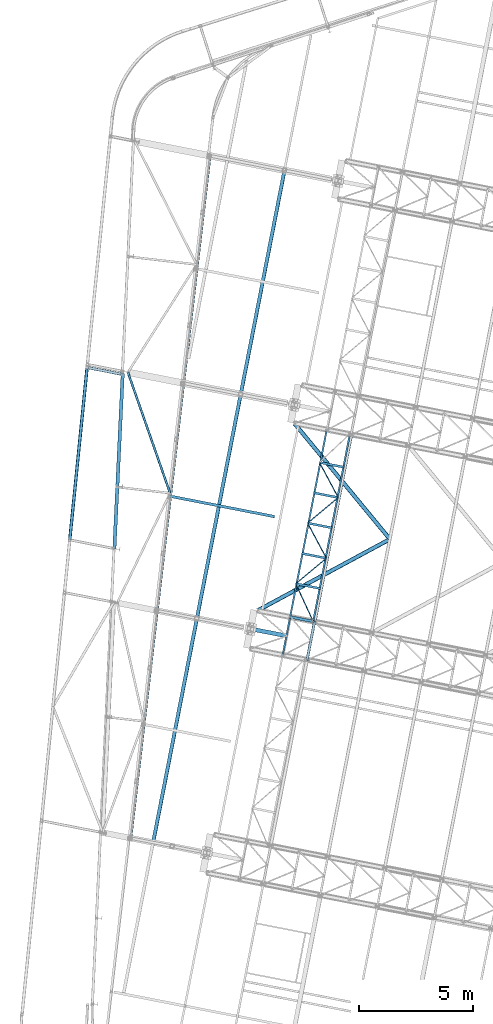
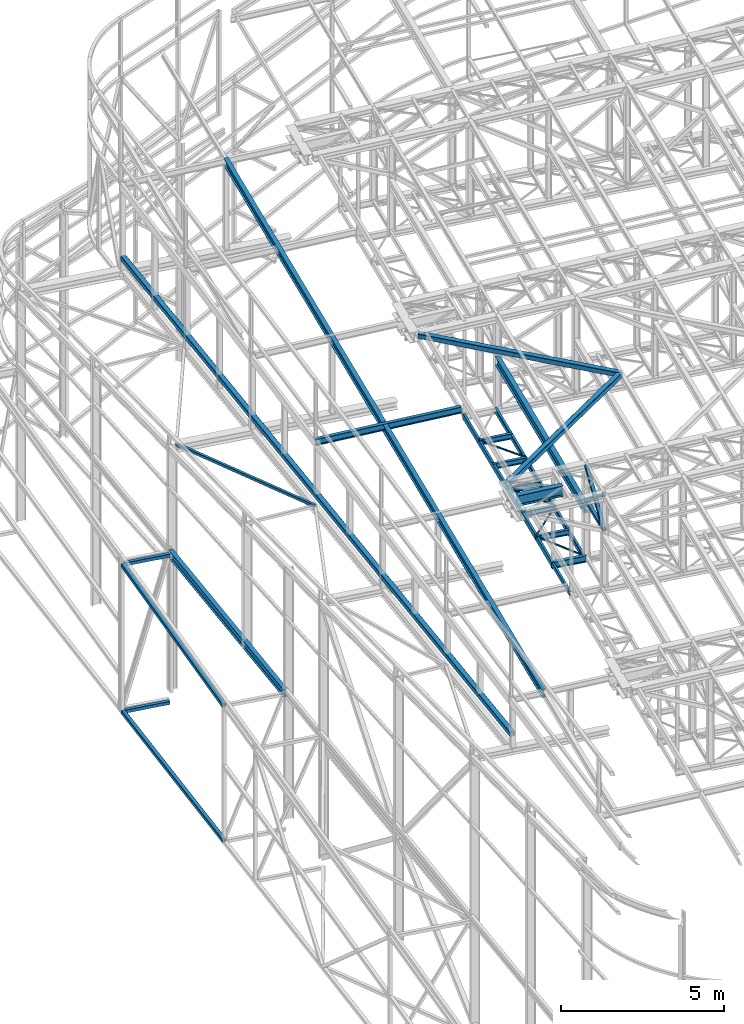
# One storey, part 70 of 215: 28 beams, 2 members, 30 elements without a shape of their own.
"""IFC2X3 building model written with IfcOpenShell, lengths in millimetres."""

from ifc_helpers import new_model, si_unit, frame, origin_with_axes, origin_2d_with_axis, place, context, subcontext, project, spatial, hollow_rectangle, i_section, u_section, extrude, clip, halfspace, material, type_object, element, aggregate, save


model = new_model("IFC2X3")

# Units and contexts
model_context = context("Model", 3, precision=1e-05, world=origin_with_axes())
body_context = subcontext(model_context, "Body", "Model", "MODEL_VIEW")
ifc_project = project(units=[si_unit("LENGTHUNIT", "METRE", prefix="MILLI"), si_unit("AREAUNIT", "SQUARE_METRE"), si_unit("VOLUMEUNIT", "CUBIC_METRE"), si_unit("MASSUNIT", "GRAM", prefix="KILO"), si_unit("TIMEUNIT", "SECOND"), si_unit("PLANEANGLEUNIT", "RADIAN"), si_unit("SOLIDANGLEUNIT", "STERADIAN"), si_unit("THERMODYNAMICTEMPERATUREUNIT", "DEGREE_CELSIUS"), si_unit("LUMINOUSINTENSITYUNIT", "LUMEN")], contexts=[model_context])

# Site, building, storey
site_placement = place(None, origin_with_axes())
site = spatial("IfcSite", under=ifc_project, at=site_placement, CompositionType="ELEMENT")
building_placement = place(site_placement, origin_with_axes())
building = spatial("IfcBuilding", under=site, at=building_placement, Name="Undefined", CompositionType="ELEMENT")
storey_placement = place(building_placement, origin_with_axes())
storey = spatial("IfcBuildingStorey", under=building, at=storey_placement, Name="Undefined", CompositionType="ELEMENT", Elevation=0.0)

# Assembly, beam
assembly_1_placement = place(storey_placement, origin_with_axes())
assembly_1 = element("IfcElementAssembly", 1, at=assembly_1_placement, inside=storey, Name="Steel Assembly", AssemblyPlace="NOTDEFINED", PredefinedType="RIGID_FRAME")
ifc_material_1 = material(Name="STEEL/S355JR")
beam_type_1 = type_object("IfcBeamType", Name="IPE240", PredefinedType="NOTDEFINED")
beam_1_placement = place(assembly_1_placement, frame((45870.7197562295, 33525.8888527729, 8620.00000000187), z_axis=(0.0, 0.0, 1.0), x_axis=(0.981422409205525, -0.19185946604018, 1.89999991602007e-08)))
beam_1 = element("IfcBeam", 2, at=beam_1_placement, type_object=beam_type_1, material=ifc_material_1, ObjectType="IPE240", context=body_context, shape_type="SweptSolid", body=[
    extrude(i_section(OverallWidth=120.0, OverallDepth=240.0, WebThickness=6.199999809, FlangeThickness=9.800000191, FilletRadius=15.0, at=origin_2d_with_axis()), frame((1125.79486349449, 0.0, 0.0), z_axis=(-1.0, 0.0, 0.0), x_axis=(-6.93889390390723e-18, -1.0, -3.46944695195361e-18)), (0.0, 0.0, 1.0), 1125.8),
])
aggregate(assembly_1, [beam_1])

assembly_2_placement = place(storey_placement, origin_with_axes())
assembly_2 = element("IfcElementAssembly", 3, at=assembly_2_placement, inside=storey, Name="Steel Assembly", AssemblyPlace="NOTDEFINED", PredefinedType="RIGID_FRAME")
ifc_material_2 = material(Name="STEEL/S275JR")
beam_2_placement = place(assembly_2_placement, frame((40574.7007247499, 38820.9318714766, 11862.6457779007), z_axis=(-0.0304080349967745, 0.00594450299936818, 0.999519891893966), x_axis=(0.980951223231219, -0.191767338045201, 0.0309836360073031)))
beam_2 = element("IfcBeam", 4, at=beam_2_placement, type_object=beam_type_1, material=ifc_material_2, Name="TRAVERSE", ObjectType="IPE240", context=body_context, shape_type="SweptSolid", body=[
    extrude(i_section(OverallWidth=120.0, OverallDepth=240.0, WebThickness=6.199999809, FlangeThickness=9.800000191, FilletRadius=15.0, at=origin_2d_with_axis()), frame((4735.84548835721, -7.39508111654668e-12, 1.64307646945042e-14), z_axis=(-1.0, 0.0, 0.0), x_axis=(-6.93889390390723e-18, -1.0, -3.46944695195361e-18)), (0.0, 0.0, 1.0), 4735.8),
])
aggregate(assembly_2, [beam_2])

assembly_3_placement = place(storey_placement, origin_with_axes())
assembly_3 = element("IfcElementAssembly", 5, at=assembly_3_placement, inside=storey, Name="Steel Assembly", AssemblyPlace="NOTDEFINED", PredefinedType="RIGID_FRAME")
ifc_material_3 = material(Name="STEEL/S235JR")
beam_type_2 = type_object("IfcBeamType", PredefinedType="NOTDEFINED")
beam_3_placement = place(assembly_3_placement, frame((38507.9983066721, 44152.2773014969, 5130.81618442959), z_axis=(0.0, 0.0, 1.0), x_axis=(-0.981475092367809, 0.1915897780718, 0.0)))
beam_3 = element("IfcBeam", 6, at=beam_3_placement, type_object=beam_type_2, material=ifc_material_3, Name="LISSE", context=body_context, shape_type="SweptSolid", body=[
    extrude(hollow_rectangle(XDim=120.0, YDim=120.0, WallThickness=4.0, InnerFilletRadius=4.0, OuterFilletRadius=8.0, at=origin_2d_with_axis()), frame((1466.23896140756, -4.06963063639286e-14, -9.09494701772928e-13), z_axis=(-1.0, 0.0, 0.0), x_axis=(-6.93889390390723e-18, -1.0, -3.46944695195361e-18)), (0.0, 0.0, 1.0), 1466.2),
])
aggregate(assembly_3, [beam_3])

assembly_4_placement = place(storey_placement, origin_with_axes())
assembly_4 = element("IfcElementAssembly", 7, at=assembly_4_placement, inside=storey, Name="Steel Assembly", AssemblyPlace="NOTDEFINED", PredefinedType="RIGID_FRAME")
beam_4_placement = place(assembly_4_placement, frame((38507.9983066069, 44152.2773015299, -367.578507559147), z_axis=(0.0, 0.0, 1.0), x_axis=(-0.981475092367809, 0.1915897780718, 0.0)))
beam_4 = element("IfcBeam", 8, at=beam_4_placement, type_object=beam_type_2, material=ifc_material_3, Name="LISSE", context=body_context, shape_type="SweptSolid", body=[
    extrude(hollow_rectangle(XDim=120.0, YDim=120.0, WallThickness=4.0, InnerFilletRadius=4.0, OuterFilletRadius=8.0, at=origin_2d_with_axis()), frame((1466.23896140756, -4.06963063639286e-14, -9.09494701772928e-13), z_axis=(-1.0, 0.0, 0.0), x_axis=(-6.93889390390723e-18, -1.0, -3.46944695195361e-18)), (0.0, 0.0, 1.0), 1466.2),
])
aggregate(assembly_4, [beam_4])

assembly_5_placement = place(storey_placement, origin_with_axes())
assembly_5 = element("IfcElementAssembly", 9, at=assembly_5_placement, inside=storey, Name="Steel Assembly", AssemblyPlace="NOTDEFINED", PredefinedType="RIGID_FRAME")
beam_type_3 = type_object("IfcBeamType", PredefinedType="NOTDEFINED")
beam_5_placement = place(assembly_5_placement, frame((46649.4384347017, 31641.4766982713, 10796.0000009258), z_axis=(0.981422364268518, -0.191859461052493, -0.000300197000082615), x_axis=(0.191859470081235, 0.981422408415534, 0.0)))
beam_5 = element("IfcBeam", 10, at=beam_5_placement, type_object=beam_type_3, material=ifc_material_2, context=body_context, shape_type="SweptSolid", body=[
    extrude(hollow_rectangle(XDim=120.0, YDim=120.0, WallThickness=5.0, InnerFilletRadius=5.0, OuterFilletRadius=10.0, at=origin_2d_with_axis()), frame((1699.99999941724, 1.81898940354586e-12, 0.0), z_axis=(-1.0, 0.0, 0.0), x_axis=(-6.93889390390723e-18, -1.0, -3.46944695195361e-18)), (0.0, 0.0, 1.0), 1700.0),
])
aggregate(assembly_5, [beam_5])

assembly_6_placement = place(storey_placement, origin_with_axes())
assembly_6 = element("IfcElementAssembly", 11, at=assembly_6_placement, inside=storey, Name="Steel Assembly", AssemblyPlace="NOTDEFINED", PredefinedType="RIGID_FRAME")
beam_type_4 = type_object("IfcBeamType", PredefinedType="NOTDEFINED")
beam_6_placement = place(assembly_6_placement, frame((38802.4008406936, 44229.2659145975, 9116.34802934099), z_axis=(0.944199061956866, 0.328656952984984, -0.0217425539990071), x_axis=(0.329325113950894, -0.943148942859368, 0.0448892069933065)))
beam_6 = element("IfcBeam", 12, at=beam_6_placement, type_object=beam_type_4, material=ifc_material_2, context=body_context, shape_type="SweptSolid", body=[
    extrude(hollow_rectangle(XDim=100.0, YDim=100.0, WallThickness=5.0, InnerFilletRadius=5.0, OuterFilletRadius=10.0, at=origin_2d_with_axis()), frame((5609.32447625776, -1.8579119109592e-12, 7.05470446866834e-14), z_axis=(-1.0, 0.0, 0.0), x_axis=(-6.93889390390723e-18, -1.0, -3.46944695195361e-18)), (0.0, 0.0, 1.0), 5609.3),
])
aggregate(assembly_6, [beam_6])

assembly_7_placement = place(storey_placement, origin_with_axes())
assembly_7 = element("IfcElementAssembly", 13, at=assembly_7_placement, inside=storey, Name="Steel Assembly", AssemblyPlace="NOTDEFINED", PredefinedType="RIGID_FRAME")
beam_type_5 = type_object("IfcBeamType", PredefinedType="NOTDEFINED")
beam_7_placement = place(assembly_7_placement, frame((46153.4358061915, 34972.080709326, 8715.68808125005), z_axis=(0.0, 0.0, -1.0), x_axis=(0.419988254111175, -0.907529540240232, 0.0)))
beam_7 = element("IfcBeam", 14, at=beam_7_placement, type_object=beam_type_5, material=ifc_material_2, context=body_context, shape_type="SweptSolid", body=[
    extrude(hollow_rectangle(XDim=50.0, YDim=50.0, WallThickness=3.0, InnerFilletRadius=3.0, OuterFilletRadius=6.0, at=origin_2d_with_axis()), frame((1819.0177301871, 0.0, 0.0), z_axis=(-1.0, 0.0, 0.0), x_axis=(-6.93889390390723e-18, -1.0, -3.46944695195361e-18)), (0.0, 0.0, 1.0), 1819.0),
])
aggregate(assembly_7, [beam_7])

assembly_8_placement = place(storey_placement, origin_with_axes())
assembly_8 = element("IfcElementAssembly", 15, at=assembly_8_placement, inside=storey, Name="Steel Assembly", AssemblyPlace="NOTDEFINED", PredefinedType="RIGID_FRAME")
beam_8_placement = place(assembly_8_placement, frame((47493.9963179093, 36089.2001487748, 8715.68808125022), z_axis=(0.0, 0.0, -1.0), x_axis=(-0.768225315975549, -0.640179555979623, 0.0)))
beam_8 = element("IfcBeam", 16, at=beam_8_placement, type_object=beam_type_5, material=ifc_material_2, context=body_context, shape_type="SweptSolid", body=[
    extrude(hollow_rectangle(XDim=50.0, YDim=50.0, WallThickness=3.0, InnerFilletRadius=3.0, OuterFilletRadius=6.0, at=origin_2d_with_axis()), frame((1745.00954958407, -3.57879861879514e-13, 0.0), z_axis=(-1.0, 0.0, 0.0), x_axis=(-6.93889390390723e-18, -1.0, -3.46944695195361e-18)), (0.0, 0.0, 1.0), 1745.0),
])
aggregate(assembly_8, [beam_8])

assembly_9_placement = place(storey_placement, origin_with_axes())
assembly_9 = element("IfcElementAssembly", 17, at=assembly_9_placement, inside=storey, Name="Steel Assembly", AssemblyPlace="NOTDEFINED", PredefinedType="RIGID_FRAME")
beam_9_placement = place(assembly_9_placement, frame((46672.828634124, 37628.9216759817, 8715.68808124293), z_axis=(0.0, 0.0, -1.0), x_axis=(0.470580592231475, -0.882357017434029, 0.0)))
beam_9 = element("IfcBeam", 18, at=beam_9_placement, type_object=beam_type_5, material=ifc_material_2, context=body_context, shape_type="SweptSolid", body=[
    extrude(hollow_rectangle(XDim=50.0, YDim=50.0, WallThickness=3.0, InnerFilletRadius=3.0, OuterFilletRadius=6.0, at=origin_2d_with_axis()), frame((1745.0096693843, 0.0, 0.0), z_axis=(-1.0, 0.0, 0.0), x_axis=(-6.93889390390723e-18, -1.0, -3.46944695195361e-18)), (0.0, 0.0, 1.0), 1745.0),
])
aggregate(assembly_9, [beam_9])

assembly_10_placement = place(storey_placement, origin_with_axes())
assembly_10 = element("IfcElementAssembly", 19, at=assembly_10_placement, inside=storey, Name="Steel Assembly", AssemblyPlace="NOTDEFINED", PredefinedType="RIGID_FRAME")
beam_10_placement = place(assembly_10_placement, frame((48013.3891458419, 38746.0411154303, 8715.6880812431), z_axis=(0.0, 0.0, -1.0), x_axis=(-0.768225315975549, -0.640179555979623, 0.0)))
beam_10 = element("IfcBeam", 20, at=beam_10_placement, type_object=beam_type_5, material=ifc_material_2, context=body_context, shape_type="SweptSolid", body=[
    extrude(hollow_rectangle(XDim=50.0, YDim=50.0, WallThickness=3.0, InnerFilletRadius=3.0, OuterFilletRadius=6.0, at=origin_2d_with_axis()), frame((1745.00954958407, -3.57879861879514e-13, 0.0), z_axis=(-1.0, 0.0, 0.0), x_axis=(-6.93889390390723e-18, -1.0, -3.46944695195361e-18)), (0.0, 0.0, 1.0), 1745.0),
])
aggregate(assembly_10, [beam_10])

assembly_11_placement = place(storey_placement, origin_with_axes())
assembly_11 = element("IfcElementAssembly", 21, at=assembly_11_placement, inside=storey, Name="Steel Assembly", AssemblyPlace="NOTDEFINED", PredefinedType="RIGID_FRAME")
beam_11_placement = place(assembly_11_placement, frame((47192.2214620566, 40285.7626426373, 8715.68808123581), z_axis=(0.0, 0.0, -1.0), x_axis=(0.470580592231475, -0.882357017434029, 0.0)))
beam_11 = element("IfcBeam", 22, at=beam_11_placement, type_object=beam_type_5, material=ifc_material_2, context=body_context, shape_type="SweptSolid", body=[
    extrude(hollow_rectangle(XDim=50.0, YDim=50.0, WallThickness=3.0, InnerFilletRadius=3.0, OuterFilletRadius=6.0, at=origin_2d_with_axis()), frame((1745.0096693843, 0.0, 0.0), z_axis=(-1.0, 0.0, 0.0), x_axis=(-6.93889390390723e-18, -1.0, -3.46944695195361e-18)), (0.0, 0.0, 1.0), 1745.0),
])
aggregate(assembly_11, [beam_11])

assembly_12_placement = place(storey_placement, origin_with_axes())
assembly_12 = element("IfcElementAssembly", 23, at=assembly_12_placement, inside=storey, Name="Steel Assembly", AssemblyPlace="NOTDEFINED", PredefinedType="RIGID_FRAME")
beam_type_6 = type_object("IfcBeamType", Name="UPN200", PredefinedType="NOTDEFINED")
beam_12_placement = place(assembly_12_placement, frame((47511.7443486288, 41724.7590755779, 8640.68808126583), z_axis=(0.0, 0.0, -1.0), x_axis=(-0.191860814904866, -0.981422145513357, 0.0)))
beam_12 = element("IfcBeam", 24, at=beam_12_placement, type_object=beam_type_6, material=ifc_material_2, ObjectType="UPN200", context=body_context, shape_type="SweptSolid", body=[
    extrude(u_section(Depth=200.0, FlangeWidth=75.0, WebThickness=8.5, FlangeThickness=11.5, FilletRadius=11.5, EdgeRadius=6.0, FlangeSlope=0.0798299857122373, at=origin_2d_with_axis()), frame((8361.40106173832, 0.0, -1.81898940354586e-12), z_axis=(-1.0, 0.0, 0.0), x_axis=(-6.93889390390723e-18, -1.0, -3.46944695195361e-18)), (0.0, 0.0, 1.0), 8361.4),
])
aggregate(assembly_12, [beam_12])

assembly_13_placement = place(storey_placement, origin_with_axes())
assembly_13 = element("IfcElementAssembly", 25, at=assembly_13_placement, inside=storey, Name="Steel Assembly", AssemblyPlace="NOTDEFINED", PredefinedType="RIGID_FRAME")
beam_13_placement = place(assembly_13_placement, frame((46917.4018606128, 33321.2682468476, 8640.68808125743), z_axis=(0.0, 0.0, -1.0), x_axis=(0.192113207966546, 0.981372770829109, 0.0)))
beam_13 = element("IfcBeam", 26, at=beam_13_placement, type_object=beam_type_6, material=ifc_material_2, ObjectType="UPN200", context=body_context, shape_type="SweptSolid", body=[
    extrude(u_section(Depth=200.0, FlangeWidth=75.0, WebThickness=8.5, FlangeThickness=11.5, FilletRadius=11.5, EdgeRadius=6.0, FlangeSlope=0.0798299857122373, at=origin_2d_with_axis()), frame((8361.39860286523, 2.3207543117424e-13, 0.0), z_axis=(-1.0, 0.0, 0.0), x_axis=(-6.93889390390723e-18, -1.0, -3.46944695195361e-18)), (0.0, 0.0, 1.0), 8361.4),
])
aggregate(assembly_13, [beam_13])

# Assembly, member
assembly_14_placement = place(storey_placement, origin_with_axes())
assembly_14 = element("IfcElementAssembly", 27, at=assembly_14_placement, inside=storey, Name="Steel Assembly", AssemblyPlace="NOTDEFINED", PredefinedType="RIGID_FRAME")
member_type = type_object("IfcMemberType", PredefinedType="NOTDEFINED")
member_1_placement = place(assembly_14_placement, frame((46975.5995333865, 33309.8947920896, 10796.0000009335), z_axis=(0.981457773618154, -0.191678330925429, 0.000236765999907874), x_axis=(-0.15135681799229, -0.774238415960567, 0.614529078968702)))
member_1 = element("IfcMember", 28, at=member_1_placement, type_object=member_type, material=ifc_material_2, context=body_context, shape_type="SweptSolid", body=[
    extrude(hollow_rectangle(XDim=120.0, YDim=120.0, WallThickness=5.0, InnerFilletRadius=5.0, OuterFilletRadius=10.0, at=origin_2d_with_axis()), frame((2154.91514201782, 7.15633579384435e-12, 2.72186368544976e-14), z_axis=(-1.0, 0.0, 0.0), x_axis=(-6.93889390390723e-18, -1.0, -3.46944695195361e-18)), (0.0, 0.0, 1.0), 2154.9),
])
aggregate(assembly_14, [member_1])

assembly_15_placement = place(storey_placement, origin_with_axes())
assembly_15 = element("IfcElementAssembly", 29, at=assembly_15_placement, inside=storey, Name="Steel Assembly", AssemblyPlace="NOTDEFINED", PredefinedType="RIGID_FRAME")
member_2_placement = place(assembly_15_placement, frame((46649.4384347017, 31641.4766982713, 10796.0000009258), z_axis=(0.981457773617921, -0.191678330925384, -0.000236766999908156), x_axis=(0.151356816942679, 0.774238418706794, 0.614529075767276)))
member_2 = element("IfcMember", 30, at=member_2_placement, type_object=member_type, material=ifc_material_2, context=body_context, shape_type="SweptSolid", body=[
    extrude(hollow_rectangle(XDim=120.0, YDim=120.0, WallThickness=5.0, InnerFilletRadius=5.0, OuterFilletRadius=10.0, at=origin_2d_with_axis()), frame((2154.91514201782, 7.15633579384435e-12, 2.72186368544976e-14), z_axis=(-1.0, 0.0, 0.0), x_axis=(-6.93889390390723e-18, -1.0, -3.46944695195361e-18)), (0.0, 0.0, 1.0), 2154.9),
])
aggregate(assembly_15, [member_2])

# Assembly, beam
assembly_16_placement = place(storey_placement, origin_with_axes())
assembly_16 = element("IfcElementAssembly", 31, at=assembly_16_placement, inside=storey, Name="Steel Assembly", AssemblyPlace="NOTDEFINED", PredefinedType="RIGID_FRAME")
beam_type_7 = type_object("IfcBeamType", PredefinedType="NOTDEFINED")
beam_14_placement = place(assembly_16_placement, frame((50278.0367165614, 36924.1353338749, 12154.1206089774), z_axis=(-0.0304080349967745, 0.00594450299936818, 0.999519891893966), x_axis=(-0.879777562863468, -0.474782314926319, -0.0239414559962845)))
beam_14 = element("IfcBeam", 32, at=beam_14_placement, type_object=beam_type_7, material=ifc_material_2, context=body_context, shape_type="SweptSolid", body=[
    extrude(hollow_rectangle(XDim=180.0, YDim=180.0, WallThickness=8.0, InnerFilletRadius=12.0, OuterFilletRadius=20.0, at=origin_2d_with_axis()), frame((6586.3148658864, 6.71601352153469e-13, 0.0), z_axis=(-1.0, 0.0, 0.0), x_axis=(-6.93889390390723e-18, -1.0, -3.46944695195361e-18)), (0.0, 0.0, 1.0), 6586.3),
])
aggregate(assembly_16, [beam_14])

assembly_17_placement = place(storey_placement, origin_with_axes())
assembly_17 = element("IfcElementAssembly", 33, at=assembly_17_placement, inside=storey, Name="Steel Assembly", AssemblyPlace="NOTDEFINED", PredefinedType="RIGID_FRAME")
beam_15_placement = place(assembly_17_placement, frame((50278.0367165614, 36924.1353338749, 12154.1206089774), z_axis=(-0.0304080349967745, 0.00594450299936818, 0.999519891893966), x_axis=(-0.636209844962318, 0.771144499954326, -0.023941456998582)))
beam_15 = element("IfcBeam", 34, at=beam_15_placement, type_object=beam_type_7, material=ifc_material_2, context=body_context, shape_type="SweptSolid", body=[
    extrude(hollow_rectangle(XDim=180.0, YDim=180.0, WallThickness=8.0, InnerFilletRadius=12.0, OuterFilletRadius=20.0, at=origin_2d_with_axis()), frame((6586.31471164171, 8.67261906526822e-13, 1.84184027304677e-12), z_axis=(-1.0, 0.0, 0.0), x_axis=(-6.93889390390723e-18, -1.0, -3.46944695195361e-18)), (0.0, 0.0, 1.0), 6586.3),
])
aggregate(assembly_17, [beam_15])

assembly_18_placement = place(storey_placement, origin_with_axes())
assembly_18 = element("IfcElementAssembly", 35, at=assembly_18_placement, inside=storey, Name="Steel Assembly", AssemblyPlace="NOTDEFINED", PredefinedType="RIGID_FRAME")
beam_16_placement = place(assembly_18_placement, frame((38897.3929158741, 23848.6454767742, 10621.0731835143), z_axis=(-0.00575349199998689, -0.0495464219998568, -0.998755249997124), x_axis=(0.11520381899365, 0.992088770945314, -0.0498793609972505)))
beam_16 = element("IfcBeam", 36, at=beam_16_placement, type_object=beam_type_7, material=ifc_material_2, Name="LISSE", context=body_context, shape_type="SweptSolid", body=[
    extrude(hollow_rectangle(XDim=180.0, YDim=180.0, WallThickness=8.0, InnerFilletRadius=12.0, OuterFilletRadius=20.0, at=origin_2d_with_axis()), frame((30031.2497286765, 7.42449967482539e-12, 0.0), z_axis=(-1.0, 0.0, 0.0), x_axis=(-6.93889390390723e-18, -1.0, -3.46944695195361e-18)), (0.0, 0.0, 1.0), 30031.2),
])
aggregate(assembly_18, [beam_16])

assembly_19_placement = place(storey_placement, origin_with_axes())
assembly_19 = element("IfcElementAssembly", 37, at=assembly_19_placement, inside=storey, Name="Steel Assembly", AssemblyPlace="NOTDEFINED", PredefinedType="RIGID_FRAME")
beam_type_8 = type_object("IfcBeamType", PredefinedType="NOTDEFINED")
beam_17_placement = place(assembly_19_placement, frame((36255.606519788, 36895.6208857272, -357.578364525278), z_axis=(0.0, 0.0, 1.0), x_axis=(0.100072764036038, 0.994980121358304, -3.80000000127566e-08)))
beam_17 = element("IfcBeam", 38, at=beam_17_placement, type_object=beam_type_8, material=ifc_material_2, Name="LISSE", context=body_context, shape_type="SweptSolid", body=[
    extrude(hollow_rectangle(XDim=140.0, YDim=140.0, WallThickness=8.0, InnerFilletRadius=12.0, OuterFilletRadius=20.0, at=origin_2d_with_axis()), frame((7529.16886180471, -3.71729657660194e-12, -4.98238600889824e-20), z_axis=(-1.0, 0.0, 0.0), x_axis=(-6.93889390390723e-18, -1.0, -3.46944695195361e-18)), (0.0, 0.0, 1.0), 7529.2),
])
aggregate(assembly_19, [beam_17])

assembly_20_placement = place(storey_placement, origin_with_axes())
assembly_20 = element("IfcElementAssembly", 39, at=assembly_20_placement, inside=storey, Name="Steel Assembly", AssemblyPlace="NOTDEFINED", PredefinedType="RIGID_FRAME")
beam_18_placement = place(assembly_20_placement, frame((36256.0162030423, 36899.6941496655, 4680.41536315165), z_axis=(-0.00585262000162014, -0.0581895240161309, 0.998288398276717), x_axis=(0.0999014779774727, 0.993277111776024, 0.0584831079868125)))
beam_18 = element("IfcBeam", 40, at=beam_18_placement, type_object=beam_type_8, material=ifc_material_2, Name="LISSE", context=body_context, shape_type="Clipping", body=[
    clip(extrude(hollow_rectangle(XDim=140.0, YDim=140.0, WallThickness=8.0, InnerFilletRadius=12.0, OuterFilletRadius=20.0, at=origin_2d_with_axis()), frame((7581.71759419406, -9.68774118267047e-14, 4.02138616890965e-13), z_axis=(-1.0, 0.0, 0.0), x_axis=(-6.93889390390723e-18, -1.0, -3.46944695195361e-18)), (0.0, 0.0, 1.0), 7581.7), halfspace(frame((7604.12905571279, -80.0457749580928, 1310.40850163055), z_axis=(0.994015265805352, -0.0924090923694029, -0.0582598574781932), x_axis=(0.0585102103347113, -5.41348744988339e-08, 0.998286810133533)), False)),
])
aggregate(assembly_20, [beam_18])

assembly_21_placement = place(storey_placement, origin_with_axes())
assembly_21 = element("IfcElementAssembly", 41, at=assembly_21_placement, inside=storey, Name="Steel Assembly", AssemblyPlace="NOTDEFINED", PredefinedType="RIGID_FRAME")
beam_type_9 = type_object("IfcBeamType", Name="IPE300", PredefinedType="NOTDEFINED")
beam_19_placement = place(assembly_21_placement, frame((38210.999952981, 36526.5731312528, 4690.52347072333), z_axis=(-0.00585164299790375, -0.0581866479791405, 0.998288571642076), x_axis=(0.0475199150160084, 0.997161649335921, 0.0583995100196734)))
beam_19 = element("IfcBeam", 42, at=beam_19_placement, type_object=beam_type_9, material=ifc_material_2, Name="LISSE", ObjectType="IPE300", context=body_context, shape_type="SweptSolid", body=[
    extrude(i_section(OverallWidth=150.0, OverallDepth=300.0, WebThickness=7.099999905, FlangeThickness=10.69999981, FilletRadius=15.0, at=origin_2d_with_axis()), frame((7694.82086318049, 4.8387900681133e-14, -5.33935455791812e-14), z_axis=(-1.0, 0.0, 0.0), x_axis=(-6.93889390390723e-18, -1.0, -3.46944695195361e-18)), (0.0, 0.0, 1.0), 7694.8),
])
aggregate(assembly_21, [beam_19])

assembly_22_placement = place(storey_placement, origin_with_axes())
assembly_22 = element("IfcElementAssembly", 43, at=assembly_22_placement, inside=storey, Name="Steel Assembly", AssemblyPlace="NOTDEFINED", PredefinedType="RIGID_FRAME")
beam_20_placement = place(assembly_22_placement, frame((39906.4061290987, 23638.4425479764, 11902.5957858298), z_axis=(-0.0304080349967745, 0.00594450299936818, 0.999519891893966), x_axis=(0.191859470081235, 0.981422408415534, 0.0)))
beam_20 = element("IfcBeam", 44, at=beam_20_placement, type_object=beam_type_9, material=ifc_material_2, ObjectType="IPE300", context=body_context, shape_type="SweptSolid", body=[
    extrude(i_section(OverallWidth=150.0, OverallDepth=300.0, WebThickness=7.099999905, FlangeThickness=10.69999981, FilletRadius=15.0, at=origin_2d_with_axis()), frame((29994.1356422396, -1.75383547922504e-12, -1.8173168611647e-12), z_axis=(-1.0, 0.0, 0.0), x_axis=(-6.93889390390723e-18, -1.0, -3.46944695195361e-18)), (0.0, 0.0, 1.0), 29994.1),
])
aggregate(assembly_22, [beam_20])

assembly_23_placement = place(storey_placement, origin_with_axes())
assembly_23 = element("IfcElementAssembly", 45, at=assembly_23_placement, inside=storey, Name="Steel Assembly", AssemblyPlace="NOTDEFINED", PredefinedType="RIGID_FRAME")
beam_type_10 = type_object("IfcBeamType", Name="IPE200", PredefinedType="NOTDEFINED")
beam_21_placement = place(assembly_23_placement, frame((48273.085559808, 40074.4615987584, 8640.68808123959), z_axis=(0.0, 0.0, -1.0), x_axis=(-0.981422136295317, 0.191860862057732, 0.0)))
beam_21 = element("IfcBeam", 46, at=beam_21_placement, type_object=beam_type_10, material=ifc_material_2, ObjectType="IPE200", context=body_context, shape_type="SweptSolid", body=[
    extrude(i_section(OverallWidth=100.0, OverallDepth=200.0, WebThickness=5.599999905, FlangeThickness=8.5, FilletRadius=12.0, at=origin_2d_with_axis()), frame((1101.32435229261, 0.0, 0.0), z_axis=(-1.0, 0.0, 0.0), x_axis=(-6.93889390390723e-18, -1.0, -3.46944695195361e-18)), (0.0, 0.0, 1.0), 1101.3),
])
aggregate(assembly_23, [beam_21])

assembly_24_placement = place(storey_placement, origin_with_axes())
assembly_24 = element("IfcElementAssembly", 47, at=assembly_24_placement, inside=storey, Name="Steel Assembly", AssemblyPlace="NOTDEFINED", PredefinedType="RIGID_FRAME")
beam_22_placement = place(assembly_24_placement, frame((48013.3891458417, 38746.0411154306, 8640.68808124315), z_axis=(0.0, 0.0, -1.0), x_axis=(-0.981422136295317, 0.191860862057732, 0.0)))
beam_22 = element("IfcBeam", 48, at=beam_22_placement, type_object=beam_type_10, material=ifc_material_2, ObjectType="IPE200", context=body_context, shape_type="SweptSolid", body=[
    extrude(i_section(OverallWidth=100.0, OverallDepth=200.0, WebThickness=5.599999905, FlangeThickness=8.5, FilletRadius=12.0, at=origin_2d_with_axis()), frame((1101.32435229261, 0.0, 0.0), z_axis=(-1.0, 0.0, 0.0), x_axis=(-6.93889390390723e-18, -1.0, -3.46944695195361e-18)), (0.0, 0.0, 1.0), 1101.3),
])
aggregate(assembly_24, [beam_22])

assembly_25_placement = place(storey_placement, origin_with_axes())
assembly_25 = element("IfcElementAssembly", 49, at=assembly_25_placement, inside=storey, Name="Steel Assembly", AssemblyPlace="NOTDEFINED", PredefinedType="RIGID_FRAME")
beam_23_placement = place(assembly_25_placement, frame((47740.6782490172, 37420.1684460943, 8640.68808124667), z_axis=(0.0, 0.0, -1.0), x_axis=(-0.981422754657796, 0.1918576989331, 0.0)))
beam_23 = element("IfcBeam", 50, at=beam_23_placement, type_object=beam_type_10, material=ifc_material_2, ObjectType="IPE200", context=body_context, shape_type="SweptSolid", body=[
    extrude(i_section(OverallWidth=100.0, OverallDepth=200.0, WebThickness=5.599999905, FlangeThickness=8.5, FilletRadius=12.0, at=origin_2d_with_axis()), frame((1088.06282494011, -1.45217154183547e-11, -1.81898940354586e-12), z_axis=(-1.0, 0.0, 0.0), x_axis=(-6.93889390390723e-18, -1.0, -3.46944695195361e-18)), (0.0, 0.0, 1.0), 1088.1),
])
aggregate(assembly_25, [beam_23])

assembly_26_placement = place(storey_placement, origin_with_axes())
assembly_26 = element("IfcElementAssembly", 51, at=assembly_26_placement, inside=storey, Name="Steel Assembly", AssemblyPlace="NOTDEFINED", PredefinedType="RIGID_FRAME")
beam_24_placement = place(assembly_26_placement, frame((47493.9963179091, 36089.200148775, 8640.68808125027), z_axis=(0.0, 0.0, -1.0), x_axis=(-0.981422136295317, 0.191860862057732, 0.0)))
beam_24 = element("IfcBeam", 52, at=beam_24_placement, type_object=beam_type_10, material=ifc_material_2, ObjectType="IPE200", context=body_context, shape_type="SweptSolid", body=[
    extrude(i_section(OverallWidth=100.0, OverallDepth=200.0, WebThickness=5.599999905, FlangeThickness=8.5, FilletRadius=12.0, at=origin_2d_with_axis()), frame((1101.32435229261, 0.0, 0.0), z_axis=(-1.0, 0.0, 0.0), x_axis=(-6.93889390390723e-18, -1.0, -3.46944695195361e-18)), (0.0, 0.0, 1.0), 1101.3),
])
aggregate(assembly_26, [beam_24])

assembly_27_placement = place(storey_placement, origin_with_axes())
assembly_27 = element("IfcElementAssembly", 53, at=assembly_27_placement, inside=storey, Name="Steel Assembly", AssemblyPlace="NOTDEFINED", PredefinedType="RIGID_FRAME")
beam_25_placement = place(assembly_27_placement, frame((47234.2999039428, 34760.7796654472, 8640.68808125383), z_axis=(0.0, 0.0, -1.0), x_axis=(-0.981422136295317, 0.191860862057732, 0.0)))
beam_25 = element("IfcBeam", 54, at=beam_25_placement, type_object=beam_type_10, material=ifc_material_2, ObjectType="IPE200", context=body_context, shape_type="SweptSolid", body=[
    extrude(i_section(OverallWidth=100.0, OverallDepth=200.0, WebThickness=5.599999905, FlangeThickness=8.5, FilletRadius=12.0, at=origin_2d_with_axis()), frame((1101.32435229261, 0.0, 0.0), z_axis=(-1.0, 0.0, 0.0), x_axis=(-6.93889390390723e-18, -1.0, -3.46944695195361e-18)), (0.0, 0.0, 1.0), 1101.3),
])
aggregate(assembly_27, [beam_25])

assembly_28_placement = place(storey_placement, origin_with_axes())
assembly_28 = element("IfcElementAssembly", 55, at=assembly_28_placement, inside=storey, Name="Steel Assembly", AssemblyPlace="NOTDEFINED", PredefinedType="RIGID_FRAME")
beam_type_11 = type_object("IfcBeamType", Name="UPE160", PredefinedType="NOTDEFINED")
beam_26_placement = place(assembly_28_placement, frame((45578.908091543, 31850.753833589, 8659.90778502849), z_axis=(0.0, 0.0, 1.0), x_axis=(0.191859470081235, 0.981422408415534, 0.0)))
beam_26 = element("IfcBeam", 56, at=beam_26_placement, type_object=beam_type_11, material=ifc_material_2, ObjectType="UPE160", context=body_context, shape_type="SweptSolid", body=[
    extrude(u_section(Depth=160.0, FlangeWidth=70.0, WebThickness=5.5, FlangeThickness=9.5, FilletRadius=12.0, at=origin_2d_with_axis()), frame((1699.99999941724, 1.81898940354586e-12, 0.0), z_axis=(-1.0, 0.0, 0.0), x_axis=(-6.93889390390723e-18, -1.0, -3.46944695195361e-18)), (0.0, 0.0, 1.0), 1700.0),
])
aggregate(assembly_28, [beam_26])

assembly_29_placement = place(storey_placement, origin_with_axes())
assembly_29 = element("IfcElementAssembly", 57, at=assembly_29_placement, inside=storey, Name="Steel Assembly", AssemblyPlace="NOTDEFINED", PredefinedType="RIGID_FRAME")
beam_type_12 = type_object("IfcBeamType", Name="IPE400", PredefinedType="NOTDEFINED")
beam_27_placement = place(assembly_29_placement, frame((45773.0400723727, 32682.3808131547, 11977.2837750291), z_axis=(-0.0304353769908008, 0.00588060299822369, 0.999519437697839), x_axis=(-0.981001747706934, 0.191506346942789, -0.0309982269907395)))
beam_27 = element("IfcBeam", 58, at=beam_27_placement, type_object=beam_type_12, material=ifc_material_2, ObjectType="IPE400", context=body_context, shape_type="SweptSolid", body=[
    extrude(i_section(OverallWidth=180.0, OverallDepth=400.0, WebThickness=8.600000381, FlangeThickness=13.5, FilletRadius=21.0, at=origin_2d_with_axis()), frame((1478.40590576434, 7.23088131679995e-12, -3.63797880709171e-12), z_axis=(-1.0, 0.0, 0.0), x_axis=(-6.93889390390723e-18, -1.0, -3.46944695195361e-18)), (0.0, 0.0, 1.0), 1478.4),
])
aggregate(assembly_29, [beam_27])

assembly_30_placement = place(storey_placement, origin_with_axes())
assembly_30 = element("IfcElementAssembly", 59, at=assembly_30_placement, inside=storey, Name="Steel Assembly", AssemblyPlace="NOTDEFINED", PredefinedType="RIGID_FRAME")
beam_type_13 = type_object("IfcBeamType", Name="IPE330", PredefinedType="NOTDEFINED")
beam_28_placement = place(assembly_30_placement, frame((46975.6000725345, 33309.8944829712, 10473.250000477), z_axis=(0.0, 0.0, 1.0), x_axis=(0.191859470081235, 0.981422408415534, 0.0)))
beam_28 = element("IfcBeam", 60, at=beam_28_placement, type_object=beam_type_13, material=ifc_material_2, Name="SUPPORT", ObjectType="IPE330", context=body_context, shape_type="SweptSolid", body=[
    extrude(i_section(OverallWidth=160.0, OverallDepth=330.0, WebThickness=7.5, FlangeThickness=11.5, FilletRadius=18.0, at=origin_2d_with_axis()), frame((8361.40106173832, 0.0, -1.81898940354586e-12), z_axis=(-1.0, 0.0, 0.0), x_axis=(-6.93889390390723e-18, -1.0, -3.46944695195361e-18)), (0.0, 0.0, 1.0), 8361.4),
])
aggregate(assembly_30, [beam_28])

save(model, "model.ifc")
